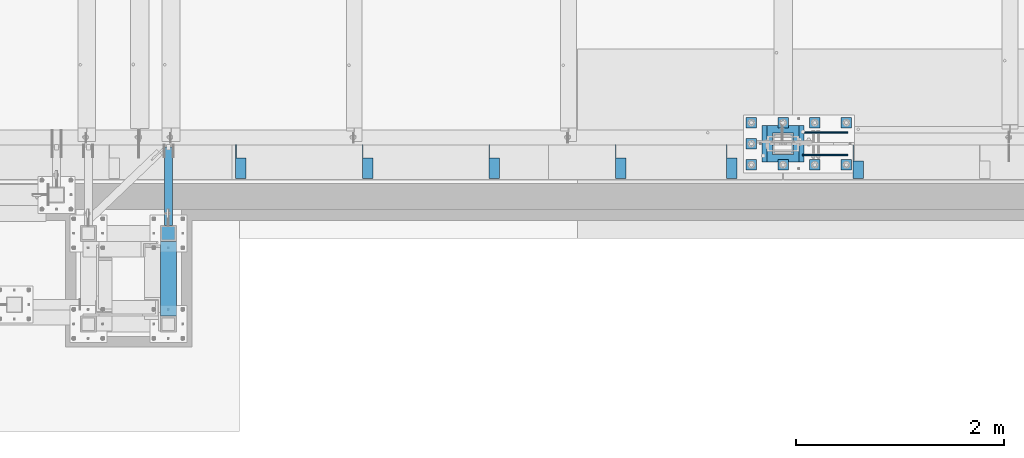
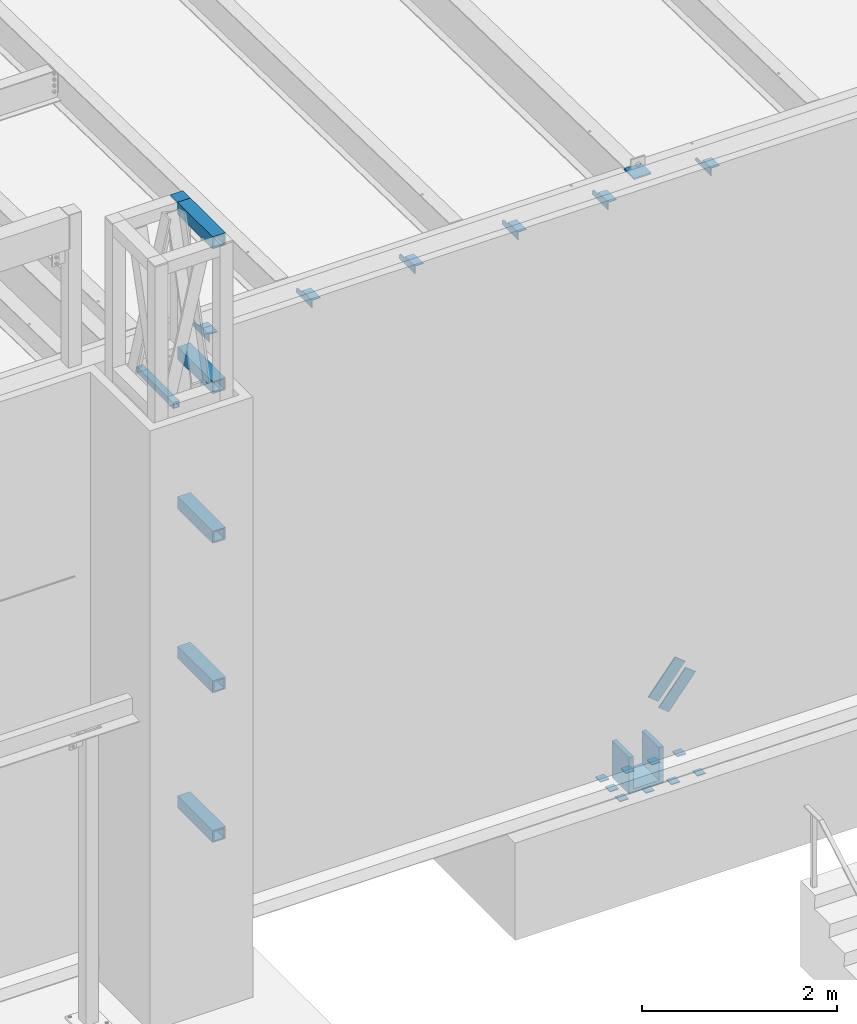
# One storey, part 1212 of 1763: 24 beams, 2 members, 8 elements without a shape of their own.
"""IFC2X3 building model written with IfcOpenShell, lengths in millimetres."""

from ifc_helpers import new_model, si_unit, frame, origin_with_axes, place, context, subcontext, project, spatial, faceted_brep, material, type_object, element, aggregate, save


model = new_model("IFC2X3")

# Units and contexts
model_context = context("Model", 3, precision=1e-05, world=origin_with_axes())
body_context = subcontext(model_context, "Body", "Model", "MODEL_VIEW")
ifc_project = project(units=[si_unit("LENGTHUNIT", "METRE", prefix="MILLI"), si_unit("AREAUNIT", "SQUARE_METRE"), si_unit("VOLUMEUNIT", "CUBIC_METRE"), si_unit("MASSUNIT", "GRAM", prefix="KILO"), si_unit("TIMEUNIT", "SECOND"), si_unit("PLANEANGLEUNIT", "RADIAN"), si_unit("SOLIDANGLEUNIT", "STERADIAN"), si_unit("THERMODYNAMICTEMPERATUREUNIT", "DEGREE_CELSIUS"), si_unit("LUMINOUSINTENSITYUNIT", "LUMEN")], contexts=[model_context])

# Site, building, storey
site_placement = place(None, origin_with_axes())
site = spatial("IfcSite", under=ifc_project, at=site_placement, CompositionType="ELEMENT")
building_placement = place(site_placement, origin_with_axes())
building = spatial("IfcBuilding", under=site, at=building_placement, Name="Undefined", CompositionType="ELEMENT")
storey_placement = place(building_placement, origin_with_axes())
storey = spatial("IfcBuildingStorey", under=building, at=storey_placement, Name="Undefined", CompositionType="ELEMENT", Elevation=0.0)

# Assembly, beam
assembly_1_placement = place(storey_placement, origin_with_axes())
assembly_1 = element("IfcElementAssembly", 1, at=assembly_1_placement, inside=storey, Name="BEAM", AssemblyPlace="NOTDEFINED", PredefinedType="RIGID_FRAME")
ifc_material_1 = material(Name="STEEL/A36")
beam_type_1 = type_object("IfcBeamType", Name="L4X4X1/4", PredefinedType="NOTDEFINED")
beam_1_placement = place(assembly_1_placement, frame((-34226.8055562795, -13727.9060686171, 12153.8999999997), z_axis=(0.0, 0.0, -1.0), x_axis=(0.0, -1.0, 0.0)))
beam_1 = element("IfcBeam", 2, at=beam_1_placement, type_object=beam_type_1, material=ifc_material_1, Name="BRACE", ObjectType="L4X4X1/4", context=body_context, shape_type="Brep", body=[
    faceted_brep([(31.7499984742426, 44.4500000000007, -6.35000000027321), (0.0, 44.4500000000007, 25.3999999997268), (0.0, 50.7999999999993, 25.3999999997268), (31.7499984742426, 50.7999999999993, -6.35000038323415), (-1.96450855582952e-10, 50.8000000000393, 50.7999999999374), (-1.81898940354586e-10, 44.4500000000371, 50.7999999999374), (324.643737794, 44.4500000000007, 50.7999999999993), (324.643737794, 50.7999999999993, 50.7999999999993), (324.643737794, -50.7999999999993, -50.7999999999993), (324.643737794, -50.7999999999993, -44.4500000000007), (156.368568202592, -50.7999999999993, -44.4500000000007), (156.368568386746, -50.7999999999993, -50.7999999999993), (324.643737794, 50.7999999999993, -50.7999999999993), (156.368568386746, 50.7999999999993, -50.7999999999993), (324.643737794, 44.4500000000007, -44.4500000000007), (156.368568202592, 44.4500000000007, -44.4500000000007), (156.368567097667, 44.4500000000007, -6.34999980941575), (156.368567097667, 50.7999999999993, -6.34999980941575)], [[[0, 1, 2, 3]], [[4, 5, 6, 7]], [[8, 9, 10, 11]], [[12, 8, 11, 13]], [[6, 14, 9, 8, 12, 7]], [[9, 14, 15, 10]], [[16, 17, 13, 11, 10, 15]], [[17, 16, 0, 3]], [[4, 7, 12, 13, 17, 3, 2]], [[5, 4, 2, 1]], [[16, 15, 14, 6, 5, 1, 0]]]),
])
aggregate(assembly_1, [beam_1])

# Assembly, beams
assembly_2_placement = place(storey_placement, origin_with_axes())
assembly_2 = element("IfcElementAssembly", 3, at=assembly_2_placement, inside=storey, Name="BEAM", AssemblyPlace="NOTDEFINED", PredefinedType="RIGID_FRAME")
beam_2_placement = place(assembly_2_placement, frame((-35446.0055562795, -13723.9373186161, 12153.8999999997), z_axis=(0.0, 0.0, -1.0), x_axis=(0.0, -1.0, 0.0)))
beam_2 = element("IfcBeam", 4, at=beam_2_placement, type_object=beam_type_1, material=ifc_material_1, Name="BRACE", ObjectType="L4X4X1/4", context=body_context, shape_type="Brep", body=[
    faceted_brep([(126.999999999967, 44.4499999999971, -25.4000000000069), (126.999999999967, 50.8000000000029, -25.4000000000069), (127.0, 50.7999999999993, -50.7999999999993), (127.0, -50.7999999999993, -50.7999999999993), (126.999999999965, -50.8000000000029, -44.4500000000007), (126.999999999965, 44.4499999999971, -44.4500000000007), (31.7499999999691, 44.4499999999971, -25.3999994277547), (31.7499999999691, 50.8000000000029, -25.3999994277547), (-1.81898940354586e-10, 44.4500000000371, 50.7999999999374), (-1.96450855582952e-10, 50.8000000000393, 50.7999999999374), (0.0, 50.8000000000029, 6.35000057224534), (0.0, 44.4499999999971, 6.35000057224534), (328.612481689444, 44.4499999999971, 50.7999999999993), (328.612481689444, 50.8000000000029, 50.7999999999993), (328.612512206997, 44.4499999999971, -44.4500000000007), (328.612512206997, -50.8000000000029, -44.4500000000007), (328.612512206997, -50.8000000000029, -50.7999999999993), (328.612512206997, 50.8000000000029, -50.7999999999993)], [[[0, 1, 2, 3, 4, 5]], [[6, 7, 1, 0]], [[8, 9, 10, 11]], [[9, 8, 12, 13]], [[12, 14, 15, 16, 17, 13]], [[15, 14, 5, 4]], [[16, 15, 4, 3]], [[17, 16, 3, 2]], [[10, 9, 13, 17, 2, 1, 7]], [[11, 10, 7, 6]], [[14, 12, 8, 11, 6, 0, 5]]]),
])
beam_3_placement = place(assembly_2_placement, frame((-36512.8055562795, -13723.9373186162, 12153.8999999998), z_axis=(0.0, 0.0, -1.0), x_axis=(0.0, -1.0, 0.0)))
beam_3 = element("IfcBeam", 5, at=beam_3_placement, type_object=beam_type_1, material=ifc_material_1, Name="BRACE", ObjectType="L4X4X1/4", context=body_context, shape_type="Brep", body=[
    faceted_brep([(126.999999999967, 44.4499999999971, -25.4000000000069), (126.999999999967, 50.8000000000029, -25.4000000000069), (127.0, 50.7999999999993, -50.7999999999993), (127.0, -50.7999999999993, -50.7999999999993), (126.999999999965, -50.8000000000029, -44.4500000000007), (126.999999999965, 44.4499999999971, -44.4500000000007), (31.7499999999691, 44.4499999999971, -25.3999994277547), (31.7499999999691, 50.8000000000029, -25.3999994277547), (-1.81898940354586e-10, 44.4500000000371, 50.7999999999374), (-1.96450855582952e-10, 50.8000000000393, 50.7999999999374), (0.0, 50.8000000000029, 6.35000057224534), (0.0, 44.4499999999971, 6.35000057224534), (328.612481689444, 44.4499999999971, 50.7999999999993), (328.612481689444, 50.8000000000029, 50.7999999999993), (328.612512206997, 44.4499999999971, -44.4500000000007), (328.612512206997, -50.8000000000029, -44.4500000000007), (328.612512206997, -50.8000000000029, -50.7999999999993), (328.612512206997, 50.8000000000029, -50.7999999999993)], [[[0, 1, 2, 3, 4, 5]], [[6, 7, 1, 0]], [[8, 9, 10, 11]], [[9, 8, 12, 13]], [[12, 14, 15, 16, 17, 13]], [[15, 14, 5, 4]], [[16, 15, 4, 3]], [[17, 16, 3, 2]], [[10, 9, 13, 17, 2, 1, 7]], [[11, 10, 7, 6]], [[14, 12, 8, 11, 6, 0, 5]]]),
])
beam_4_placement = place(assembly_2_placement, frame((-37732.0055562795, -13723.9373186163, 12153.8999999998), z_axis=(0.0, 0.0, -1.0), x_axis=(0.0, -1.0, 0.0)))
beam_4 = element("IfcBeam", 6, at=beam_4_placement, type_object=beam_type_1, material=ifc_material_1, Name="BRACE", ObjectType="L4X4X1/4", context=body_context, shape_type="Brep", body=[
    faceted_brep([(126.999999999967, 44.4499999999971, -25.4000000000069), (126.999999999967, 50.8000000000029, -25.4000000000069), (127.0, 50.7999999999993, -50.7999999999993), (127.0, -50.7999999999993, -50.7999999999993), (126.999999999965, -50.8000000000029, -44.4500000000007), (126.999999999965, 44.4499999999971, -44.4500000000007), (31.7499999999691, 44.4499999999971, -25.3999994277547), (31.7499999999691, 50.8000000000029, -25.3999994277547), (-1.81898940354586e-10, 44.4500000000371, 50.7999999999374), (-1.96450855582952e-10, 50.8000000000393, 50.7999999999374), (0.0, 50.8000000000029, 6.35000057224534), (0.0, 44.4499999999971, 6.35000057224534), (328.612481689444, 44.4499999999971, 50.7999999999993), (328.612481689444, 50.8000000000029, 50.7999999999993), (328.612512206997, 44.4499999999971, -44.4500000000007), (328.612512206997, -50.8000000000029, -44.4500000000007), (328.612512206997, -50.8000000000029, -50.7999999999993), (328.612512206997, 50.8000000000029, -50.7999999999993)], [[[0, 1, 2, 3, 4, 5]], [[6, 7, 1, 0]], [[8, 9, 10, 11]], [[9, 8, 12, 13]], [[12, 14, 15, 16, 17, 13]], [[15, 14, 5, 4]], [[16, 15, 4, 3]], [[17, 16, 3, 2]], [[10, 9, 13, 17, 2, 1, 7]], [[11, 10, 7, 6]], [[14, 12, 8, 11, 6, 0, 5]]]),
])
beam_5_placement = place(assembly_2_placement, frame((-38951.2055562795, -13723.9373186164, 12153.8999999998), z_axis=(0.0, 0.0, -1.0), x_axis=(0.0, -1.0, 0.0)))
beam_5 = element("IfcBeam", 7, at=beam_5_placement, type_object=beam_type_1, material=ifc_material_1, Name="BRACE", ObjectType="L4X4X1/4", context=body_context, shape_type="Brep", body=[
    faceted_brep([(126.999999999967, 44.4499999999971, -25.4000000000069), (126.999999999967, 50.8000000000029, -25.4000000000069), (127.0, 50.7999999999993, -50.7999999999993), (127.0, -50.7999999999993, -50.7999999999993), (126.999999999965, -50.8000000000029, -44.4500000000007), (126.999999999965, 44.4499999999971, -44.4500000000007), (31.7499999999691, 44.4499999999971, -25.3999994277547), (31.7499999999691, 50.8000000000029, -25.3999994277547), (-1.81898940354586e-10, 44.4500000000371, 50.7999999999374), (-1.96450855582952e-10, 50.8000000000393, 50.7999999999374), (0.0, 50.8000000000029, 6.35000057224534), (0.0, 44.4499999999971, 6.35000057224534), (328.612481689444, 44.4499999999971, 50.7999999999993), (328.612481689444, 50.8000000000029, 50.7999999999993), (328.612512206997, 44.4499999999971, -44.4500000000007), (328.612512206997, -50.8000000000029, -44.4500000000007), (328.612512206997, -50.8000000000029, -50.7999999999993), (328.612512206997, 50.8000000000029, -50.7999999999993)], [[[0, 1, 2, 3, 4, 5]], [[6, 7, 1, 0]], [[8, 9, 10, 11]], [[9, 8, 12, 13]], [[12, 14, 15, 16, 17, 13]], [[15, 14, 5, 4]], [[16, 15, 4, 3]], [[17, 16, 3, 2]], [[10, 9, 13, 17, 2, 1, 7]], [[11, 10, 7, 6]], [[14, 12, 8, 11, 6, 0, 5]]]),
])
beam_6_placement = place(assembly_2_placement, frame((-40170.4055562795, -13723.9373186165, 12153.8999999998), z_axis=(0.0, 0.0, -1.0), x_axis=(0.0, -1.0, 0.0)))
beam_6 = element("IfcBeam", 8, at=beam_6_placement, type_object=beam_type_1, material=ifc_material_1, Name="BRACE", ObjectType="L4X4X1/4", context=body_context, shape_type="Brep", body=[
    faceted_brep([(126.999999999967, 44.4499999999971, -25.4000000000069), (126.999999999967, 50.8000000000029, -25.4000000000069), (127.0, 50.7999999999993, -50.7999999999993), (127.0, -50.7999999999993, -50.7999999999993), (126.999999999965, -50.8000000000029, -44.4500000000007), (126.999999999965, 44.4499999999971, -44.4500000000007), (31.7499999999691, 44.4499999999971, -25.3999994277547), (31.7499999999691, 50.8000000000029, -25.3999994277547), (-1.81898940354586e-10, 44.4500000000371, 50.7999999999374), (-1.96450855582952e-10, 50.8000000000393, 50.7999999999374), (0.0, 50.8000000000029, 6.35000057224534), (0.0, 44.4499999999971, 6.35000057224534), (328.612481689444, 44.4499999999971, 50.7999999999993), (328.612481689444, 50.8000000000029, 50.7999999999993), (328.612512206997, 44.4499999999971, -44.4500000000007), (328.612512206997, -50.8000000000029, -44.4500000000007), (328.612512206997, -50.8000000000029, -50.7999999999993), (328.612512206997, 50.8000000000029, -50.7999999999993)], [[[0, 1, 2, 3, 4, 5]], [[6, 7, 1, 0]], [[8, 9, 10, 11]], [[9, 8, 12, 13]], [[12, 14, 15, 16, 17, 13]], [[15, 14, 5, 4]], [[16, 15, 4, 3]], [[17, 16, 3, 2]], [[10, 9, 13, 17, 2, 1, 7]], [[11, 10, 7, 6]], [[14, 12, 8, 11, 6, 0, 5]]]),
])
aggregate(assembly_2, [beam_2, beam_3, beam_4, beam_5, beam_6])

# Assembly, beam
assembly_3_placement = place(storey_placement, origin_with_axes())
assembly_3 = element("IfcElementAssembly", 9, at=assembly_3_placement, inside=storey, Name="BEAM", AssemblyPlace="NOTDEFINED", PredefinedType="RIGID_FRAME")
ifc_material_2 = material()
beam_type_2 = type_object("IfcBeamType", Name="HSS3X3X1/4", PredefinedType="NOTDEFINED")
beam_7_placement = place(assembly_3_placement, frame((-40868.0384959181, -14503.3306029674, 11820.525), z_axis=(0.0, 0.0, 1.0), x_axis=(0.0, 1.0, 0.0)))
beam_7 = element("IfcBeam", 10, at=beam_7_placement, type_object=beam_type_2, material=ifc_material_2, Name="BEAM", ObjectType="HSS3X3X1/4", context=body_context, shape_type="Brep", body=[
    faceted_brep([(0.0, 31.75, -31.75), (0.0, -31.75, -31.75), (753.993284350292, -31.75, -31.75), (753.993284350292, 31.75, -31.75), (0.0, -31.75, 31.75), (753.993284350292, -31.75, 31.75), (0.0, 31.75, 31.75), (753.993284350292, 31.75, 31.75), (0.0, 38.0999999999985, -38.1000000000004), (0.0, 38.0999999999985, 38.1000000000004), (753.993284350292, 38.0999999999985, 38.1000000000004), (753.993284350292, 38.0999999999985, -38.1000000000004), (0.0, -38.0999999999985, 38.1000000000004), (753.993284350292, -38.0999999999985, 38.1000000000004), (0.0, -38.0999999999985, -38.1000000000004), (753.993284350292, -38.0999999999985, -38.1000000000004)], [[[0, 1, 2, 3]], [[1, 4, 5, 2]], [[4, 6, 7, 5]], [[6, 0, 3, 7]], [[8, 9, 10, 11]], [[9, 12, 13, 10]], [[12, 14, 15, 13]], [[14, 8, 11, 15]], [[13, 15, 11, 10], [5, 7, 3, 2]], [[14, 12, 9, 8], [6, 4, 1, 0]]]),
])
aggregate(assembly_3, [beam_7])

# Assembly, beams
assembly_4_placement = place(storey_placement, origin_with_axes())
assembly_4 = element("IfcElementAssembly", 11, at=assembly_4_placement, inside=storey, Name="FRAME", AssemblyPlace="NOTDEFINED", PredefinedType="RIGID_FRAME")
beam_type_3 = type_object("IfcBeamType", PredefinedType="NOTDEFINED")
beam_8_placement = place(assembly_4_placement, frame((-40868.0383006056, -14655.7306029674, 14468.475), z_axis=(1.0, 0.0, 0.0), x_axis=(0.0, 1.0, 0.0)))
beam_8 = element("IfcBeam", 12, at=beam_8_placement, type_object=beam_type_3, material=ifc_material_1, Name="PLATE", context=body_context, shape_type="Brep", body=[
    faceted_brep([(0.0, 9.52499999999964, -76.1999999999971), (0.0, 9.52499999999964, 76.1999999999971), (152.400000000001, 9.52499999999964, 76.1999999999971), (152.400000000001, 9.52499999999964, -76.1999999999971), (0.0, -9.52499999999964, 76.1999999999971), (152.400000000001, -9.52499999999964, 76.1999999999971), (0.0, -9.52499999999964, -76.1999999999971), (152.400000000001, -9.52499999999964, -76.1999999999971)], [[[0, 1, 2, 3]], [[1, 4, 5, 2]], [[4, 6, 7, 5]], [[6, 0, 3, 7]], [[5, 7, 3, 2]], [[6, 4, 1, 0]]]),
])
beam_type_4 = type_object("IfcBeamType", Name="HSS6X6X5/8", PredefinedType="NOTDEFINED")
beam_9_placement = place(assembly_4_placement, frame((-40868.0383006091, -15452.6556029674, 6966.7437499986), z_axis=(0.0, 0.0, 1.0), x_axis=(0.0, 1.0, 0.0)))
beam_9 = element("IfcBeam", 13, at=beam_9_placement, type_object=beam_type_4, material=ifc_material_2, Name="BEAM", ObjectType="HSS6X6X5/8", context=body_context, shape_type="Brep", body=[
    faceted_brep([(76.1999511718459, 60.3250000000007, -60.3250000000007), (76.1999511718459, -60.3250000000007, -60.3250000000007), (796.924999999999, -60.3249999999971, -60.3249999999998), (796.924999999999, 60.3249999999971, -60.3249999999998), (76.1999511718459, -60.3250000000007, 60.3250000000007), (796.924999999999, -60.3249999999971, 60.3249999999998), (76.1999511718459, 60.3250000000007, 60.3250000000007), (796.924999999999, 60.3249999999971, 60.3249999999998), (76.1999511718459, 76.2000000000007, -76.2000000000007), (76.1999511718459, 76.2000000000007, 76.2000000000007), (796.924999999999, 76.1999999999971, 76.1999999999998), (796.924999999999, 76.1999999999971, -76.1999999999998), (76.1999511718459, -76.2000000000007, 76.2000000000007), (796.924999999999, -76.1999999999971, 76.1999999999998), (76.1999511718459, -76.2000000000007, -76.2000000000007), (796.924999999999, -76.1999999999971, -76.1999999999998)], [[[0, 1, 2, 3]], [[1, 4, 5, 2]], [[4, 6, 7, 5]], [[6, 0, 3, 7]], [[8, 9, 10, 11]], [[9, 12, 13, 10]], [[12, 14, 15, 13]], [[14, 8, 11, 15]], [[13, 15, 11, 10], [5, 7, 3, 2]], [[14, 12, 9, 8], [6, 4, 1, 0]]]),
])
beam_10_placement = place(assembly_4_placement, frame((-40868.0383006125, -15452.6556029674, 8840.7874999986), z_axis=(0.0, 0.0, 1.0), x_axis=(0.0, 1.0, 0.0)))
beam_10 = element("IfcBeam", 14, at=beam_10_placement, type_object=beam_type_4, material=ifc_material_2, Name="BEAM", ObjectType="HSS6X6X5/8", context=body_context, shape_type="Brep", body=[
    faceted_brep([(76.1999511718459, 60.3250000000007, -60.3250000000007), (76.1999511718459, -60.3250000000007, -60.3250000000007), (796.924999999999, -60.3249999999971, -60.3249999999998), (796.924999999999, 60.3249999999971, -60.3249999999998), (76.1999511718459, -60.3250000000007, 60.3250000000007), (796.924999999999, -60.3249999999971, 60.3249999999998), (76.1999511718459, 60.3250000000007, 60.3250000000007), (796.924999999999, 60.3249999999971, 60.3249999999998), (76.1999511718459, 76.2000000000007, -76.2000000000007), (76.1999511718459, 76.2000000000007, 76.2000000000007), (796.924999999999, 76.1999999999971, 76.1999999999998), (796.924999999999, 76.1999999999971, -76.1999999999998), (76.1999511718459, -76.2000000000007, 76.2000000000007), (796.924999999999, -76.1999999999971, 76.1999999999998), (76.1999511718459, -76.2000000000007, -76.2000000000007), (796.924999999999, -76.1999999999971, -76.1999999999998)], [[[0, 1, 2, 3]], [[1, 4, 5, 2]], [[4, 6, 7, 5]], [[6, 0, 3, 7]], [[8, 9, 10, 11]], [[9, 12, 13, 10]], [[12, 14, 15, 13]], [[14, 8, 11, 15]], [[13, 15, 11, 10], [5, 7, 3, 2]], [[14, 12, 9, 8], [6, 4, 1, 0]]]),
])
beam_11_placement = place(assembly_4_placement, frame((-40868.0383006159, -15452.6556029674, 10714.8312499986), z_axis=(0.0, 0.0, 1.0), x_axis=(0.0, 1.0, 0.0)))
beam_11 = element("IfcBeam", 15, at=beam_11_placement, type_object=beam_type_4, material=ifc_material_2, Name="BEAM", ObjectType="HSS6X6X5/8", context=body_context, shape_type="Brep", body=[
    faceted_brep([(76.1999511718459, 60.3250000000007, -60.3250000000007), (76.1999511718459, -60.3250000000007, -60.3250000000007), (796.924999999999, -60.3249999999971, -60.3249999999998), (796.924999999999, 60.3249999999971, -60.3249999999998), (76.1999511718459, -60.3250000000007, 60.3250000000007), (796.924999999999, -60.3249999999971, 60.3249999999998), (76.1999511718459, 60.3250000000007, 60.3250000000007), (796.924999999999, 60.3249999999971, 60.3249999999998), (76.1999511718459, 76.2000000000007, -76.2000000000007), (76.1999511718459, 76.2000000000007, 76.2000000000007), (796.924999999999, 76.1999999999971, 76.1999999999998), (796.924999999999, 76.1999999999971, -76.1999999999998), (76.1999511718459, -76.2000000000007, 76.2000000000007), (796.924999999999, -76.1999999999971, 76.1999999999998), (76.1999511718459, -76.2000000000007, -76.2000000000007), (796.924999999999, -76.1999999999971, -76.1999999999998)], [[[0, 1, 2, 3]], [[1, 4, 5, 2]], [[4, 6, 7, 5]], [[6, 0, 3, 7]], [[8, 9, 10, 11]], [[9, 12, 13, 10]], [[12, 14, 15, 13]], [[14, 8, 11, 15]], [[13, 15, 11, 10], [5, 7, 3, 2]], [[14, 12, 9, 8], [6, 4, 1, 0]]]),
])
beam_12_placement = place(assembly_4_placement, frame((-40868.0383006226, -15452.6556029674, 14401.7999999986), z_axis=(0.0, 0.0, 1.0), x_axis=(0.0, 1.0, 0.0)))
beam_12 = element("IfcBeam", 16, at=beam_12_placement, type_object=beam_type_4, material=ifc_material_2, Name="BEAM", ObjectType="HSS6X6X5/8", context=body_context, shape_type="Brep", body=[
    faceted_brep([(76.1999511718459, 60.3250000000007, -60.3250000000007), (76.1999511718459, -60.3250000000007, -60.3250000000007), (796.924999999999, -60.3249999999971, -60.3249999999998), (796.924999999999, 60.3249999999971, -60.3249999999998), (76.1999511718459, -60.3250000000007, 60.3250000000007), (796.924999999999, -60.3249999999971, 60.3249999999998), (76.1999511718459, 60.3250000000007, 60.3250000000007), (796.924999999999, 60.3249999999971, 60.3249999999998), (76.1999511718459, 76.2000000000007, -76.2000000000007), (76.1999511718459, 76.2000000000007, 76.2000000000007), (796.924999999999, 76.1999999999971, 76.1999999999998), (796.924999999999, 76.1999999999971, -76.1999999999998), (76.1999511718459, -76.2000000000007, 76.2000000000007), (796.924999999999, -76.1999999999971, 76.1999999999998), (76.1999511718459, -76.2000000000007, -76.2000000000007), (796.924999999999, -76.1999999999971, -76.1999999999998)], [[[0, 1, 2, 3]], [[1, 4, 5, 2]], [[4, 6, 7, 5]], [[6, 0, 3, 7]], [[8, 9, 10, 11]], [[9, 12, 13, 10]], [[12, 14, 15, 13]], [[14, 8, 11, 15]], [[13, 15, 11, 10], [5, 7, 3, 2]], [[14, 12, 9, 8], [6, 4, 1, 0]]]),
])
beam_13_placement = place(assembly_4_placement, frame((-40868.0383006194, -15452.6556029674, 12588.8749999986), z_axis=(0.0, 0.0, 1.0), x_axis=(0.0, 1.0, 0.0)))
beam_13 = element("IfcBeam", 17, at=beam_13_placement, type_object=beam_type_4, material=ifc_material_2, Name="BEAM", ObjectType="HSS6X6X5/8", context=body_context, shape_type="Brep", body=[
    faceted_brep([(76.1999511718459, 60.3250000000007, -60.3250000000007), (76.1999511718459, -60.3250000000007, -60.3250000000007), (796.924999999999, -60.3249999999971, -60.3249999999998), (796.924999999999, 60.3249999999971, -60.3249999999998), (76.1999511718459, -60.3250000000007, 60.3250000000007), (796.924999999999, -60.3249999999971, 60.3249999999998), (76.1999511718459, 60.3250000000007, 60.3250000000007), (796.924999999999, 60.3249999999971, 60.3249999999998), (76.1999511718459, 76.2000000000007, -76.2000000000007), (76.1999511718459, 76.2000000000007, 76.2000000000007), (796.924999999999, 76.1999999999971, 76.1999999999998), (796.924999999999, 76.1999999999971, -76.1999999999998), (76.1999511718459, -76.2000000000007, 76.2000000000007), (796.924999999999, -76.1999999999971, 76.1999999999998), (76.1999511718459, -76.2000000000007, -76.2000000000007), (796.924999999999, -76.1999999999971, -76.1999999999998)], [[[0, 1, 2, 3]], [[1, 4, 5, 2]], [[4, 6, 7, 5]], [[6, 0, 3, 7]], [[8, 9, 10, 11]], [[9, 12, 13, 10]], [[12, 14, 15, 13]], [[14, 8, 11, 15]], [[13, 15, 11, 10], [5, 7, 3, 2]], [[14, 12, 9, 8], [6, 4, 1, 0]]]),
])
aggregate(assembly_4, [beam_9, beam_10, beam_11, beam_12, beam_13, beam_8])

# Assembly, members
assembly_5_placement = place(storey_placement, origin_with_axes())
assembly_5 = element("IfcElementAssembly", 18, at=assembly_5_placement, inside=storey, Name="V. BRACE", AssemblyPlace="NOTDEFINED", PredefinedType="RIGID_FRAME")
member_type = type_object("IfcMemberType", PredefinedType="NOTDEFINED")
member_1_placement = place(assembly_5_placement, frame((-34386.0225709537, -13823.95, 5826.876238688), z_axis=(-0.777142613013369, 0.0, 0.629324526010828), x_axis=(-0.629324526010829, 0.0, -0.777142613013368)))
member_1 = element("IfcMember", 19, at=member_1_placement, type_object=member_type, material=ifc_material_1, Name="PLATE", context=body_context, shape_type="Brep", body=[
    faceted_brep([(4.36557456851006e-11, 6.35000000000036, -76.2000000000044), (-4.72937244921923e-11, 6.35000000000036, 76.1999999999898), (507.999999999498, 6.35000000000036, 76.1999999995642), (507.999999999589, 6.35000000000036, -76.20000000043), (-4.72937244921923e-11, -6.35000000000036, 76.1999999999898), (507.999999999498, -6.35000000000036, 76.1999999995642), (4.36557456851006e-11, -6.35000000000036, -76.2000000000044), (507.999999999589, -6.35000000000036, -76.20000000043)], [[[0, 1, 2, 3]], [[1, 4, 5, 2]], [[4, 6, 7, 5]], [[6, 0, 3, 7]], [[5, 7, 3, 2]], [[6, 4, 1, 0]]]),
])
member_2_placement = place(assembly_5_placement, frame((-34386.0225709537, -13608.05, 5826.876238688), z_axis=(-0.777142613013369, 0.0, 0.629324526010828), x_axis=(-0.629324526010829, 0.0, -0.777142613013368)))
member_2 = element("IfcMember", 20, at=member_2_placement, type_object=member_type, material=ifc_material_1, Name="PLATE", context=body_context, shape_type="Brep", body=[
    faceted_brep([(4.36557456851006e-11, 6.35000000000036, -76.2000000000044), (-4.72937244921923e-11, 6.35000000000036, 76.1999999999898), (507.999999999498, 6.35000000000036, 76.1999999995642), (507.999999999589, 6.35000000000036, -76.20000000043), (-4.72937244921923e-11, -6.35000000000036, 76.1999999999898), (507.999999999498, -6.35000000000036, 76.1999999995642), (4.36557456851006e-11, -6.35000000000036, -76.2000000000044), (507.999999999589, -6.35000000000036, -76.20000000043)], [[[0, 1, 2, 3]], [[1, 4, 5, 2]], [[4, 6, 7, 5]], [[6, 0, 3, 7]], [[5, 7, 3, 2]], [[6, 4, 1, 0]]]),
])
aggregate(assembly_5, [member_1, member_2])

# Assembly, beams
assembly_6_placement = place(storey_placement, origin_with_axes())
assembly_6 = element("IfcElementAssembly", 21, at=assembly_6_placement, inside=storey, Name="TEMPLATE", AssemblyPlace="NOTDEFINED", PredefinedType="RIGID_FRAME")
beam_type_5 = type_object("IfcBeamType", PredefinedType="NOTDEFINED")
beam_14_placement = place(assembly_6_placement, frame((-35254.6372736983, -13970.0, 4578.35), z_axis=(1.0, 0.0, 0.0), x_axis=(0.0, 1.0, 0.0)))
beam_14 = element("IfcBeam", 22, at=beam_14_placement, type_object=beam_type_5, material=ifc_material_1, Name="WASHER PLATE", context=body_context, shape_type="Brep", body=[
    faceted_brep([(0.0, 6.35000000000036, -50.8000000000029), (0.0, 6.35000000000036, 50.8000000000029), (101.599999999999, 6.35000000000036, 50.8000000000029), (101.599999999999, 6.35000000000036, -50.8000000000029), (0.0, -6.35000000000036, 50.8000000000029), (101.599999999999, -6.35000000000036, 50.8000000000029), (0.0, -6.35000000000036, -50.8000000000029), (101.599999999999, -6.35000000000036, -50.8000000000029)], [[[0, 1, 2, 3]], [[1, 4, 5, 2]], [[4, 6, 7, 5]], [[6, 0, 3, 7]], [[5, 7, 3, 2]], [[6, 4, 1, 0]]]),
])
beam_15_placement = place(assembly_6_placement, frame((-34949.8372736984, -13970.0, 4578.35), z_axis=(1.0, 0.0, 0.0), x_axis=(0.0, 1.0, 0.0)))
beam_15 = element("IfcBeam", 23, at=beam_15_placement, type_object=beam_type_5, material=ifc_material_1, Name="WASHER PLATE", context=body_context, shape_type="Brep", body=[
    faceted_brep([(0.0, 6.35000000000036, -50.8000000000029), (0.0, 6.35000000000036, 50.8000000000029), (101.599999999999, 6.35000000000036, 50.8000000000029), (101.599999999999, 6.35000000000036, -50.8000000000029), (0.0, -6.35000000000036, 50.8000000000029), (101.599999999999, -6.35000000000036, 50.8000000000029), (0.0, -6.35000000000036, -50.8000000000029), (101.599999999999, -6.35000000000036, -50.8000000000029)], [[[0, 1, 2, 3]], [[1, 4, 5, 2]], [[4, 6, 7, 5]], [[6, 0, 3, 7]], [[5, 7, 3, 2]], [[6, 4, 1, 0]]]),
])
beam_16_placement = place(assembly_6_placement, frame((-34645.0372736983, -13970.0, 4578.35), z_axis=(1.0, 0.0, 0.0), x_axis=(0.0, 1.0, 0.0)))
beam_16 = element("IfcBeam", 24, at=beam_16_placement, type_object=beam_type_5, material=ifc_material_1, Name="WASHER PLATE", context=body_context, shape_type="Brep", body=[
    faceted_brep([(0.0, 6.35000000000036, -50.8000000000029), (0.0, 6.35000000000036, 50.8000000000029), (101.599999999999, 6.35000000000036, 50.8000000000029), (101.599999999999, 6.35000000000036, -50.8000000000029), (0.0, -6.35000000000036, 50.8000000000029), (101.599999999999, -6.35000000000036, 50.8000000000029), (0.0, -6.35000000000036, -50.8000000000029), (101.599999999999, -6.35000000000036, -50.8000000000029)], [[[0, 1, 2, 3]], [[1, 4, 5, 2]], [[4, 6, 7, 5]], [[6, 0, 3, 7]], [[5, 7, 3, 2]], [[6, 4, 1, 0]]]),
])
beam_17_placement = place(assembly_6_placement, frame((-34340.2372736983, -13970.0, 4578.35), z_axis=(1.0, 0.0, 0.0), x_axis=(0.0, 1.0, 0.0)))
beam_17 = element("IfcBeam", 25, at=beam_17_placement, type_object=beam_type_5, material=ifc_material_1, Name="WASHER PLATE", context=body_context, shape_type="Brep", body=[
    faceted_brep([(0.0, 6.35000000000036, -50.8000000000029), (0.0, 6.35000000000036, 50.8000000000029), (101.599999999999, 6.35000000000036, 50.8000000000029), (101.599999999999, 6.35000000000036, -50.8000000000029), (0.0, -6.35000000000036, 50.8000000000029), (101.599999999999, -6.35000000000036, 50.8000000000029), (0.0, -6.35000000000036, -50.8000000000029), (101.599999999999, -6.35000000000036, -50.8000000000029)], [[[0, 1, 2, 3]], [[1, 4, 5, 2]], [[4, 6, 7, 5]], [[6, 0, 3, 7]], [[5, 7, 3, 2]], [[6, 4, 1, 0]]]),
])
beam_18_placement = place(assembly_6_placement, frame((-35254.6372736983, -13766.8, 4578.35), z_axis=(1.0, 0.0, 0.0), x_axis=(0.0, 1.0, 0.0)))
beam_18 = element("IfcBeam", 26, at=beam_18_placement, type_object=beam_type_5, material=ifc_material_1, Name="WASHER PLATE", context=body_context, shape_type="Brep", body=[
    faceted_brep([(0.0, 6.35000000000036, -50.8000000000029), (0.0, 6.35000000000036, 50.8000000000029), (101.599999999999, 6.35000000000036, 50.8000000000029), (101.599999999999, 6.35000000000036, -50.8000000000029), (0.0, -6.35000000000036, 50.8000000000029), (101.599999999999, -6.35000000000036, 50.8000000000029), (0.0, -6.35000000000036, -50.8000000000029), (101.599999999999, -6.35000000000036, -50.8000000000029)], [[[0, 1, 2, 3]], [[1, 4, 5, 2]], [[4, 6, 7, 5]], [[6, 0, 3, 7]], [[5, 7, 3, 2]], [[6, 4, 1, 0]]]),
])
beam_19_placement = place(assembly_6_placement, frame((-35254.6372736983, -13563.6, 4578.35), z_axis=(1.0, 0.0, 0.0), x_axis=(0.0, 1.0, 0.0)))
beam_19 = element("IfcBeam", 27, at=beam_19_placement, type_object=beam_type_5, material=ifc_material_1, Name="WASHER PLATE", context=body_context, shape_type="Brep", body=[
    faceted_brep([(0.0, 6.35000000000036, -50.8000000000029), (0.0, 6.35000000000036, 50.8000000000029), (101.599999999999, 6.35000000000036, 50.8000000000029), (101.599999999999, 6.35000000000036, -50.8000000000029), (0.0, -6.35000000000036, 50.8000000000029), (101.599999999999, -6.35000000000036, 50.8000000000029), (0.0, -6.35000000000036, -50.8000000000029), (101.599999999999, -6.35000000000036, -50.8000000000029)], [[[0, 1, 2, 3]], [[1, 4, 5, 2]], [[4, 6, 7, 5]], [[6, 0, 3, 7]], [[5, 7, 3, 2]], [[6, 4, 1, 0]]]),
])
beam_20_placement = place(assembly_6_placement, frame((-34949.8372736984, -13563.6, 4578.35), z_axis=(1.0, 0.0, 0.0), x_axis=(0.0, 1.0, 0.0)))
beam_20 = element("IfcBeam", 28, at=beam_20_placement, type_object=beam_type_5, material=ifc_material_1, Name="WASHER PLATE", context=body_context, shape_type="Brep", body=[
    faceted_brep([(0.0, 6.35000000000036, -50.8000000000029), (0.0, 6.35000000000036, 50.8000000000029), (101.599999999999, 6.35000000000036, 50.8000000000029), (101.599999999999, 6.35000000000036, -50.8000000000029), (0.0, -6.35000000000036, 50.8000000000029), (101.599999999999, -6.35000000000036, 50.8000000000029), (0.0, -6.35000000000036, -50.8000000000029), (101.599999999999, -6.35000000000036, -50.8000000000029)], [[[0, 1, 2, 3]], [[1, 4, 5, 2]], [[4, 6, 7, 5]], [[6, 0, 3, 7]], [[5, 7, 3, 2]], [[6, 4, 1, 0]]]),
])
beam_21_placement = place(assembly_6_placement, frame((-34645.0372736983, -13563.6, 4578.35), z_axis=(1.0, 0.0, 0.0), x_axis=(0.0, 1.0, 0.0)))
beam_21 = element("IfcBeam", 29, at=beam_21_placement, type_object=beam_type_5, material=ifc_material_1, Name="WASHER PLATE", context=body_context, shape_type="Brep", body=[
    faceted_brep([(0.0, 6.35000000000036, -50.8000000000029), (0.0, 6.35000000000036, 50.8000000000029), (101.599999999999, 6.35000000000036, 50.8000000000029), (101.599999999999, 6.35000000000036, -50.8000000000029), (0.0, -6.35000000000036, 50.8000000000029), (101.599999999999, -6.35000000000036, 50.8000000000029), (0.0, -6.35000000000036, -50.8000000000029), (101.599999999999, -6.35000000000036, -50.8000000000029)], [[[0, 1, 2, 3]], [[1, 4, 5, 2]], [[4, 6, 7, 5]], [[6, 0, 3, 7]], [[5, 7, 3, 2]], [[6, 4, 1, 0]]]),
])
beam_22_placement = place(assembly_6_placement, frame((-34340.2372736983, -13563.6, 4578.35), z_axis=(1.0, 0.0, 0.0), x_axis=(0.0, 1.0, 0.0)))
beam_22 = element("IfcBeam", 30, at=beam_22_placement, type_object=beam_type_5, material=ifc_material_1, Name="WASHER PLATE", context=body_context, shape_type="Brep", body=[
    faceted_brep([(0.0, 6.35000000000036, -50.8000000000029), (0.0, 6.35000000000036, 50.8000000000029), (101.599999999999, 6.35000000000036, 50.8000000000029), (101.599999999999, 6.35000000000036, -50.8000000000029), (0.0, -6.35000000000036, 50.8000000000029), (101.599999999999, -6.35000000000036, 50.8000000000029), (0.0, -6.35000000000036, -50.8000000000029), (101.599999999999, -6.35000000000036, -50.8000000000029)], [[[0, 1, 2, 3]], [[1, 4, 5, 2]], [[4, 6, 7, 5]], [[6, 0, 3, 7]], [[5, 7, 3, 2]], [[6, 4, 1, 0]]]),
])
aggregate(assembly_6, [beam_14, beam_15, beam_16, beam_17, beam_18, beam_19, beam_20, beam_21, beam_22])

# Assembly, beam
assembly_7_placement = place(storey_placement, origin_with_axes())
assembly_7 = element("IfcElementAssembly", 31, at=assembly_7_placement, inside=storey, Name="GROUT", AssemblyPlace="NOTDEFINED", PredefinedType="REINFORCEMENT_UNIT")
ifc_material_3 = material(Name="CONCRETE/GROUT")
beam_type_6 = type_object("IfcBeamType", PredefinedType="NOTDEFINED")
beam_23_placement = place(assembly_7_placement, frame((-35127.6372736983, -13716.0325861983, 5029.19999389649), z_axis=(0.0, 1.0, 0.0), x_axis=(0.0, 0.0, -1.0)))
beam_23 = element("IfcBeam", 32, at=beam_23_placement, type_object=beam_type_6, material=ifc_material_3, Name="GROUT", context=body_context, shape_type="Brep", body=[
    faceted_brep([(0.0, -25.4000000000015, -177.799999999999), (0.0, -25.4000000000015, 177.799999999999), (0.0, 25.4000000000015, 177.799999999999), (0.0, 25.4000000000015, -177.799999999999), (457.199993896478, 25.4000000000015, 177.799999999999), (457.199993896478, 25.4000000000015, -177.799999999999), (406.399993896479, -25.4000000000015, -177.799999999999), (406.399993896479, -25.4000000000015, 177.799999999999), (457.199993896478, -380.999987792959, 177.799999999999), (457.199993896478, -380.999987792959, -177.799999999999), (406.399993896479, -330.199987792956, -177.799999999999), (406.399993896479, -330.199987792956, 177.799999999999), (3.63797880709171e-12, -380.999987792959, 177.799999999999), (3.63797880709171e-12, -380.999987792959, -177.799999999999), (3.63797880709171e-12, -330.199987792956, 177.799999999999), (3.63797880709171e-12, -330.199987792956, -177.799999999999)], [[[0, 1, 2, 3]], [[3, 2, 4, 5]], [[1, 0, 6, 7]], [[5, 4, 8, 9]], [[7, 6, 10, 11]], [[9, 8, 12, 13]], [[8, 4, 2, 1, 7, 11, 14, 12]], [[11, 10, 15, 14]], [[10, 6, 0, 3, 5, 9, 13, 15]], [[14, 15, 13, 12]]]),
])
aggregate(assembly_7, [beam_23])

assembly_8_placement = place(storey_placement, origin_with_axes())
assembly_8 = element("IfcElementAssembly", 33, at=assembly_8_placement, inside=storey, Name="COLUMN", AssemblyPlace="NOTDEFINED", PredefinedType="RIGID_FRAME")
ifc_material_4 = material(Name="STEEL/A572-50")
beam_type_7 = type_object("IfcBeamType", PredefinedType="NOTDEFINED")
beam_24_placement = place(assembly_8_placement, frame((-34949.8372736984, -13817.6, 12195.175), z_axis=(1.0, 0.0, 0.0), x_axis=(0.0, 1.0, 0.0)))
beam_24 = element("IfcBeam", 34, at=beam_24_placement, type_object=beam_type_7, material=ifc_material_4, Name="PLATE", context=body_context, shape_type="Brep", body=[
    faceted_brep([(0.0, 9.52499999999964, -101.599999999999), (0.0, 9.52499999999964, 101.599999999999), (203.200000000001, 9.52499999999964, 101.599999999999), (203.200000000001, 9.52499999999964, -101.599999999999), (0.0, -9.52499999999964, 101.599999999999), (203.200000000001, -9.52499999999964, 101.599999999999), (0.0, -9.52499999999964, -101.599999999999), (203.200000000001, -9.52499999999964, -101.599999999999)], [[[0, 1, 2, 3]], [[1, 4, 5, 2]], [[4, 6, 7, 5]], [[6, 0, 3, 7]], [[5, 7, 3, 2]], [[6, 4, 1, 0]]]),
])
aggregate(assembly_8, [beam_24])

save(model, "model.ifc")
